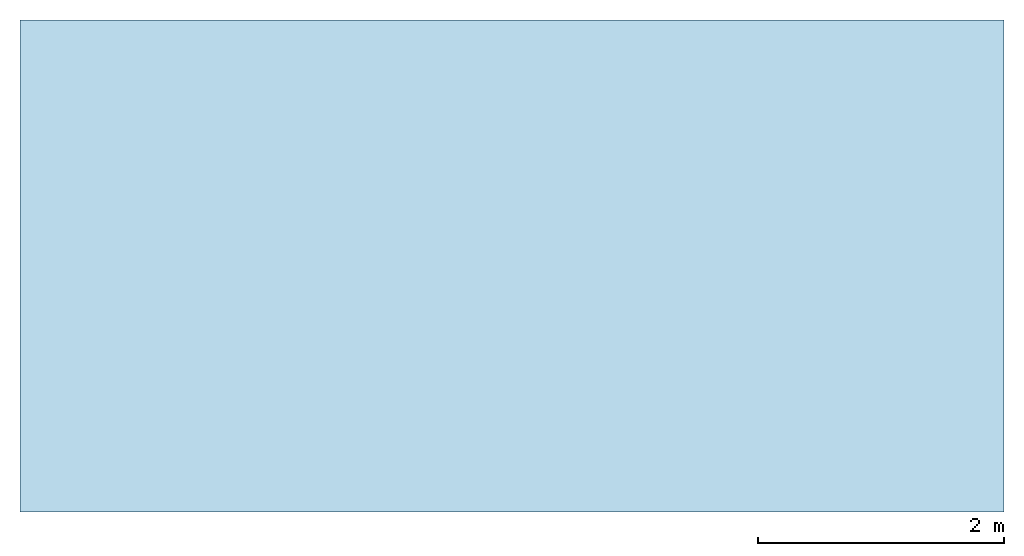
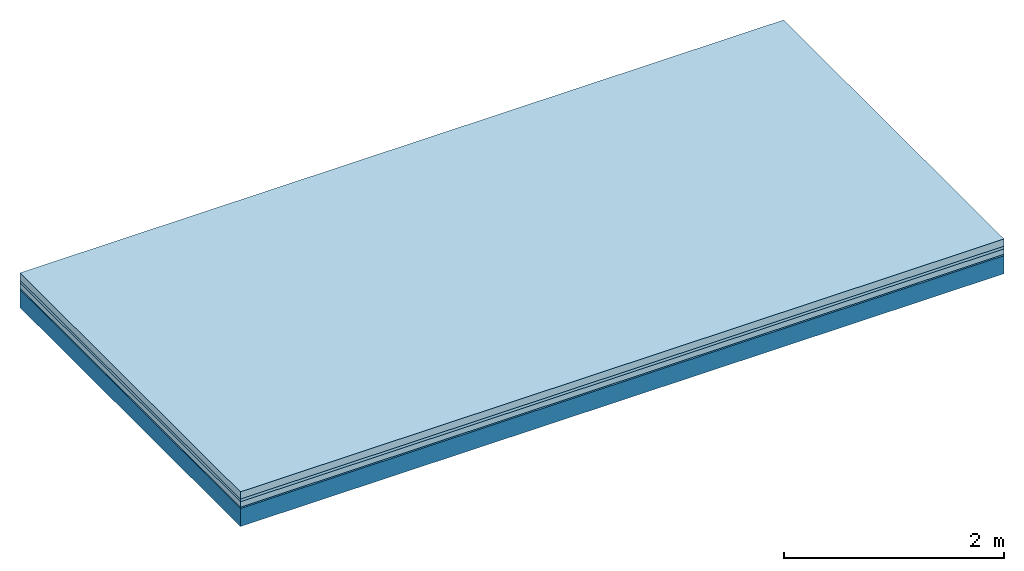
# One storey: 4 plates, 1 member, 1 element without a shape of its own.
"""IFC4 building model written with IfcOpenShell, lengths in metres."""

from ifc_helpers import new_model, si_unit, derived_unit, direction, frame, frame_2d, origin, origin_with_axes, place, context, project, spatial, rectangle, extrude, material, layer, layer_set, type_object, element, aggregate, save


model = new_model("IFC4")

# Units and contexts
plan_context = context("Plan", 3, precision=1e-05, world=origin(), true_north=direction((0.0, 1.0)))
model_context = context("Model", 3, precision=1e-05, world=origin(), true_north=direction((0.0, 1.0)))
ifc_project = project(units=[si_unit("LENGTHUNIT", "METRE"), derived_unit("SOUNDPRESSUREUNIT", [(si_unit("PRESSUREUNIT", "PASCAL", prefix="MICRO"), 0)]), si_unit("ENERGYUNIT", "JOULE", prefix="MEGA"), si_unit("MASSUNIT", "GRAM", prefix="KILO"), derived_unit("THERMALTRANSMITTANCEUNIT", [(si_unit("POWERUNIT", "WATT"), 1), (si_unit("AREAUNIT", "SQUARE_METRE"), -1), (si_unit("THERMODYNAMICTEMPERATUREUNIT", "KELVIN"), -1)]), derived_unit("AREADENSITYUNIT", [(si_unit("MASSUNIT", "GRAM", prefix="KILO"), 1), (si_unit("AREAUNIT", "SQUARE_METRE"), -1)]), derived_unit("USERDEFINED", [(si_unit("ENERGYUNIT", "JOULE", prefix="MEGA"), 1), (si_unit("AREAUNIT", "SQUARE_METRE"), -1)])], contexts=[plan_context, model_context])

# Site, building, storey
site = spatial("IfcSite", under=ifc_project)
building_placement = place(None, origin())
building = spatial("IfcBuilding", under=site, at=building_placement)
storey_placement = place(building_placement, origin())
storey = spatial("IfcBuildingStorey", under=building, at=storey_placement)

# Slab, member, plates
ifc_material_1 = material(Name="Cement screed", Category="04.006")
ifc_layer_1 = layer(ifc_material_1, 0.08, Name="On-material")
ifc_material_2 = material()
ifc_layer_2 = layer(ifc_material_2, 0.03, Name="Impact sound insulation")
ifc_material_3 = material(Category="03.011")
ifc_layer_3 = layer(ifc_material_3, 0.06, Name="on Supporting structure")
ifc_material_4 = material(Category="03.007")
ifc_layer_4 = layer(ifc_material_4, 0.015, Name="Sub-floor")
ifc_material_5 = material(Name="of the art")
ifc_layer_5 = layer(ifc_material_5, 0.0, Name="Bond")
ifc_layer_6 = layer(None, 0.2, Name="Supporting structure")
ifc_layer_set = layer_set([ifc_layer_1, ifc_layer_2, ifc_layer_3, ifc_layer_4, ifc_layer_5, ifc_layer_6])
slab_type = type_object("IfcSlabType", Name="A1093", PredefinedType="NOTDEFINED", material=ifc_layer_set)
slab_placement = place(None, frame((0.0, 0.0, 0.0), z_axis=(0.0, 0.0, -1.0), x_axis=(1.0, 0.0, 0.0)))
slab = element("IfcSlab", 1, at=slab_placement, inside=storey, type_object=slab_type, material=ifc_layer_set, Name="Slab #1")
ifc_material_6 = material()
member_placement = place(slab_placement, origin())
member = element("IfcMember", 2, at=member_placement, material=ifc_material_6, Name="Supporting structure", context=plan_context, shape_type="SweptSolid", body=[
    extrude(rectangle(XDim=1.0, YDim=0.2, at=frame_2d((0.5, 0.1), x_axis=(1.0, 0.0))), frame((0.0, 4.0, 0.185), z_axis=(0.0, -1.0, 0.0), x_axis=(1.0, 0.0, 0.0)), (0.0, 0.0, 1.0), 4.0),
    extrude(rectangle(XDim=1.0, YDim=0.2, at=frame_2d((0.5, 0.1), x_axis=(1.0, 0.0))), frame((1.0, 4.0, 0.185), z_axis=(0.0, -1.0, 0.0), x_axis=(1.0, 0.0, 0.0)), (0.0, 0.0, 1.0), 4.0),
    extrude(rectangle(XDim=1.0, YDim=0.2, at=frame_2d((0.5, 0.1), x_axis=(1.0, 0.0))), frame((2.0, 4.0, 0.185), z_axis=(0.0, -1.0, 0.0), x_axis=(1.0, 0.0, 0.0)), (0.0, 0.0, 1.0), 4.0),
    extrude(rectangle(XDim=1.0, YDim=0.2, at=frame_2d((0.5, 0.1), x_axis=(1.0, 0.0))), frame((3.0, 4.0, 0.185), z_axis=(0.0, -1.0, 0.0), x_axis=(1.0, 0.0, 0.0)), (0.0, 0.0, 1.0), 4.0),
    extrude(rectangle(XDim=1.0, YDim=0.2, at=frame_2d((0.5, 0.1), x_axis=(1.0, 0.0))), frame((4.0, 4.0, 0.185), z_axis=(0.0, -1.0, 0.0), x_axis=(1.0, 0.0, 0.0)), (0.0, 0.0, 1.0), 4.0),
    extrude(rectangle(XDim=1.0, YDim=0.2, at=frame_2d((0.5, 0.1), x_axis=(1.0, 0.0))), frame((5.0, 4.0, 0.185), z_axis=(0.0, -1.0, 0.0), x_axis=(1.0, 0.0, 0.0)), (0.0, 0.0, 1.0), 4.0),
    extrude(rectangle(XDim=1.0, YDim=0.2, at=frame_2d((0.5, 0.1), x_axis=(1.0, 0.0))), frame((6.0, 4.0, 0.185), z_axis=(0.0, -1.0, 0.0), x_axis=(1.0, 0.0, 0.0)), (0.0, 0.0, 1.0), 4.0),
    extrude(rectangle(XDim=1.0, YDim=0.2, at=frame_2d((0.5, 0.1), x_axis=(1.0, 0.0))), frame((7.0, 4.0, 0.185), z_axis=(0.0, -1.0, 0.0), x_axis=(1.0, 0.0, 0.0)), (0.0, 0.0, 1.0), 4.0),
])
plate_1_placement = place(slab_placement, origin())
plate_1 = element("IfcPlate", 3, at=plate_1_placement, material=ifc_material_1, Name="On-material", context=plan_context, shape_type="SweptSolid", body=[
    extrude(rectangle(XDim=8.0, YDim=4.0, at=frame_2d((4.0, 2.0), x_axis=(1.0, 0.0))), origin_with_axes(), (0.0, 0.0, 1.0), 0.08),
])
plate_2_placement = place(slab_placement, origin())
plate_2 = element("IfcPlate", 4, at=plate_2_placement, material=ifc_material_2, Name="Impact sound insulation", context=plan_context, shape_type="SweptSolid", body=[
    extrude(rectangle(XDim=8.0, YDim=4.0, at=frame_2d((4.0, 2.0), x_axis=(1.0, 0.0))), frame((0.0, 0.0, 0.08), z_axis=(0.0, 0.0, 1.0), x_axis=(1.0, 0.0, 0.0)), (0.0, 0.0, 1.0), 0.03),
])
plate_3_placement = place(slab_placement, origin())
plate_3 = element("IfcPlate", 5, at=plate_3_placement, material=ifc_material_3, Name="on Supporting structure", context=plan_context, shape_type="SweptSolid", body=[
    extrude(rectangle(XDim=8.0, YDim=4.0, at=frame_2d((4.0, 2.0), x_axis=(1.0, 0.0))), frame((0.0, 0.0, 0.11), z_axis=(0.0, 0.0, 1.0), x_axis=(1.0, 0.0, 0.0)), (0.0, 0.0, 1.0), 0.06),
])
plate_4_placement = place(slab_placement, origin())
plate_4 = element("IfcPlate", 6, at=plate_4_placement, material=ifc_material_4, Name="Sub-floor", context=plan_context, shape_type="SweptSolid", body=[
    extrude(rectangle(XDim=8.0, YDim=4.0, at=frame_2d((4.0, 2.0), x_axis=(1.0, 0.0))), frame((0.0, 0.0, 0.17), z_axis=(0.0, 0.0, 1.0), x_axis=(1.0, 0.0, 0.0)), (0.0, 0.0, 1.0), 0.015),
])
aggregate(slab, [plate_1, plate_2, plate_3, plate_4, member])

save(model, "model.ifc")
